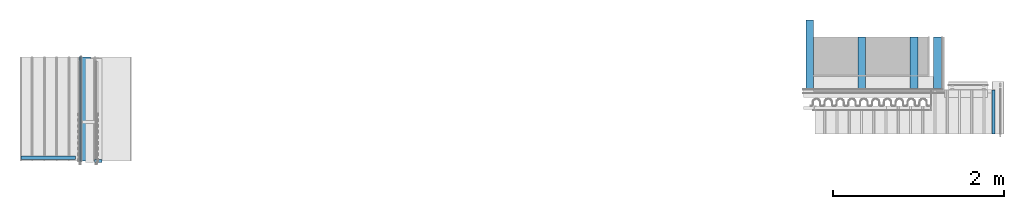
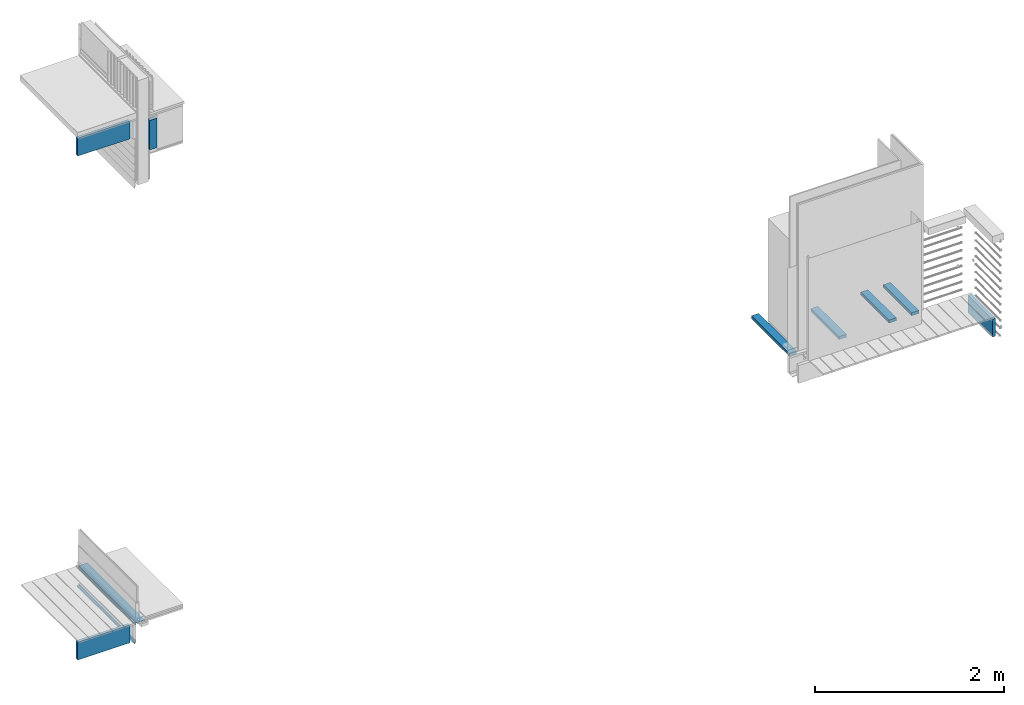
# One storey, part 3 of 33: 12 walls.
"""IFC4 building model written with IfcOpenShell, lengths in feet."""

from ifc_helpers import new_model, entity, si_unit, converted_unit, derived_unit, direction, frame, frame_2d, origin, origin_2d_with_axis, place, context, subcontext, project, spatial, rectangle, extrude, material, type_object, element, save


model = new_model("IFC4")

# Units and contexts
model_context = context("Model", 3, precision=0.0001, world=origin(), true_north=direction((6.12303176911189e-17, 1.0)))
body_context = subcontext(model_context, "Body", "Model", "MODEL_VIEW")
ifc_project = project(units=[converted_unit("LENGTHUNIT", "FOOT", entity("IfcRatioMeasure", 0.3048), si_unit("LENGTHUNIT", "METRE"), dimensions=[1, 0, 0, 0, 0, 0, 0]), converted_unit("AREAUNIT", "SQUARE FOOT", entity("IfcRatioMeasure", 0.09290304), si_unit("AREAUNIT", "SQUARE_METRE"), dimensions=[2, 0, 0, 0, 0, 0, 0]), converted_unit("VOLUMEUNIT", "CUBIC FOOT", entity("IfcRatioMeasure", 0.028316846592), si_unit("VOLUMEUNIT", "CUBIC_METRE"), dimensions=[3, 0, 0, 0, 0, 0, 0]), converted_unit("PLANEANGLEUNIT", "DEGREE", entity("IfcRatioMeasure", 0.0174532925199433), si_unit("PLANEANGLEUNIT", "RADIAN"), dimensions=[0, 0, 0, 0, 0, 0, 0]), si_unit("MASSUNIT", "GRAM", prefix="KILO"), derived_unit("MASSDENSITYUNIT", [(si_unit("MASSUNIT", "GRAM", prefix="KILO"), 1), (si_unit("LENGTHUNIT", "METRE"), -3)]), derived_unit("MOMENTOFINERTIAUNIT", [(si_unit("LENGTHUNIT", "METRE"), 4)]), si_unit("TIMEUNIT", "SECOND"), si_unit("FREQUENCYUNIT", "HERTZ"), si_unit("THERMODYNAMICTEMPERATUREUNIT", "DEGREE_CELSIUS"), derived_unit("THERMALTRANSMITTANCEUNIT", [(si_unit("MASSUNIT", "GRAM", prefix="KILO"), 1), (si_unit("THERMODYNAMICTEMPERATUREUNIT", "KELVIN"), -1), (si_unit("TIMEUNIT", "SECOND"), -3)]), derived_unit("VOLUMETRICFLOWRATEUNIT", [(si_unit("LENGTHUNIT", "METRE"), 3), (si_unit("TIMEUNIT", "SECOND"), -1)]), si_unit("ELECTRICCURRENTUNIT", "AMPERE"), si_unit("ELECTRICVOLTAGEUNIT", "VOLT"), si_unit("POWERUNIT", "WATT"), si_unit("FORCEUNIT", "NEWTON"), si_unit("ILLUMINANCEUNIT", "LUX"), si_unit("LUMINOUSFLUXUNIT", "LUMEN"), si_unit("LUMINOUSINTENSITYUNIT", "CANDELA"), derived_unit("USERDEFINED", [(si_unit("MASSUNIT", "GRAM", prefix="KILO"), -1), (si_unit("LENGTHUNIT", "METRE"), -2), (si_unit("TIMEUNIT", "SECOND"), 3), (si_unit("LUMINOUSFLUXUNIT", "LUMEN"), 1)]), derived_unit("LINEARVELOCITYUNIT", [(si_unit("LENGTHUNIT", "METRE"), 1), (si_unit("TIMEUNIT", "SECOND"), -1)]), si_unit("PRESSUREUNIT", "PASCAL"), derived_unit("USERDEFINED", [(si_unit("LENGTHUNIT", "METRE"), -2), (si_unit("MASSUNIT", "GRAM", prefix="KILO"), 1), (si_unit("TIMEUNIT", "SECOND"), -2)]), derived_unit("LINEARFORCEUNIT", [(si_unit("MASSUNIT", "GRAM", prefix="KILO"), 1), (si_unit("LENGTHUNIT", "METRE"), 1), (si_unit("TIMEUNIT", "SECOND"), -2), (si_unit("LENGTHUNIT", "METRE"), -1)]), derived_unit("PLANARFORCEUNIT", [(si_unit("MASSUNIT", "GRAM", prefix="KILO"), 1), (si_unit("LENGTHUNIT", "METRE"), 1), (si_unit("TIMEUNIT", "SECOND"), -2), (si_unit("LENGTHUNIT", "METRE"), -2)])], contexts=[model_context])

# Site, building, storey
site_placement = place(None, origin())
site = spatial("IfcSite", under=ifc_project, at=site_placement, CompositionType="ELEMENT")
building_placement = place(site_placement, origin())
building = spatial("IfcBuilding", under=site, at=building_placement, CompositionType="ELEMENT")
storey_placement = place(building_placement, frame((0.0, 0.0, 10.0)))
storey = spatial("IfcBuildingStorey", under=building, at=storey_placement, Name="2ND FLOOR", CompositionType="ELEMENT", Elevation=10.0000000000002)

# Walls
ifc_material_1 = material(Name="2X10 JOISTS", Category="Materials")
wall_type_1 = type_object("IfcWallType", Name="Generic Models 640:Generic Models 1", PredefinedType="NOTDEFINED", material=ifc_material_1)
wall_1_placement = place(storey_placement, frame((1456.95945835455, 2.06770833332915, -0.136897457209544)))
element("IfcWall", 1, at=wall_1_placement, inside=storey, type_object=wall_type_1, material=ifc_material_1, Name="Generic Models 640:Generic Models 1", ObjectType="Generic Models 640:Generic Models 1", PredefinedType="NOTDEFINED", context=body_context, shape_type="SweptSolid", body=[
    extrude(rectangle(XDim=0.125000000000002, YDim=2.09466288714884, at=origin_2d_with_axis()), frame((1.04733144357442, 0.0625000000000062, 0.0), z_axis=(0.0, 0.0, 1.0), x_axis=(0.0, 1.0, 0.0)), (0.0, 0.0, 1.0), 0.75),
])
ifc_material_2 = material(Name="METAL FLASHING", Category="Materials")
wall_type_2 = type_object("IfcWallType", Name="Generic Models 677:Generic Models 1", PredefinedType="NOTDEFINED", material=ifc_material_2)
wall_2_placement = place(storey_placement, frame((1459.20382006859, 2.0, -0.195608483354219), z_axis=(0.0, 0.0, 1.0), x_axis=(0.0, 1.0, 0.0)))
cartesian_point_1 = entity("IfcCartesianPoint", [4.0, -0.0556819070638994, 0.136863440335031])
vertex_point_1 = entity("IfcVertexPoint", cartesian_point_1)
cartesian_point_2 = entity("IfcCartesianPoint", [4.0, -0.0590152403972297, 0.136863440335031])
vertex_point_2 = entity("IfcVertexPoint", cartesian_point_2)
ifc_direction_1 = entity("IfcDirection", [0.0, -1.0, 0.0])
edge_curve_1 = entity("IfcEdgeCurve", vertex_point_1, vertex_point_2, entity("IfcTrimmedCurve", entity("IfcLine", cartesian_point_1, entity("IfcVector", ifc_direction_1, 1.0)), [cartesian_point_1], [cartesian_point_2], True, "CARTESIAN"), True)
cartesian_point_3 = entity("IfcCartesianPoint", [4.0, -0.0590152403972297, 0.0530392484579103])
vertex_point_3 = entity("IfcVertexPoint", cartesian_point_3)
ifc_direction_2 = entity("IfcDirection", [0.0, 0.0, -1.0])
edge_curve_2 = entity("IfcEdgeCurve", vertex_point_2, vertex_point_3, entity("IfcTrimmedCurve", entity("IfcLine", cartesian_point_2, entity("IfcVector", ifc_direction_2, 1.0)), [cartesian_point_2], [cartesian_point_3], True, "CARTESIAN"), True)
cartesian_point_4 = entity("IfcCartesianPoint", [4.0, -0.00778096922499572, 0.0530392484579103])
vertex_point_4 = entity("IfcVertexPoint", cartesian_point_4)
ifc_direction_3 = entity("IfcDirection", [0.0, 1.0, 0.0])
edge_curve_3 = entity("IfcEdgeCurve", vertex_point_3, vertex_point_4, entity("IfcTrimmedCurve", entity("IfcLine", cartesian_point_3, entity("IfcVector", ifc_direction_3, 1.0)), [cartesian_point_3], [cartesian_point_4], True, "CARTESIAN"), True)
cartesian_point_5 = entity("IfcCartesianPoint", [4.0, -0.00326697603304638, 0.0])
vertex_point_5 = entity("IfcVertexPoint", cartesian_point_5)
edge_curve_4 = entity("IfcEdgeCurve", vertex_point_4, vertex_point_5, entity("IfcTrimmedCurve", entity("IfcLine", cartesian_point_4, entity("IfcVector", entity("IfcDirection", [0.0, 0.0848001027005372, -0.996397984031471]), 1.0)), [cartesian_point_4], [cartesian_point_5], True, "CARTESIAN"), True)
cartesian_point_6 = entity("IfcCartesianPoint", [4.0, 0.0, 0.0])
vertex_point_6 = entity("IfcVertexPoint", cartesian_point_6)
edge_curve_5 = entity("IfcEdgeCurve", vertex_point_5, vertex_point_6, entity("IfcTrimmedCurve", entity("IfcLine", cartesian_point_5, entity("IfcVector", ifc_direction_3, 1.0)), [cartesian_point_5], [cartesian_point_6], True, "CARTESIAN"), True)
cartesian_point_7 = entity("IfcCartesianPoint", [4.0, -0.00480094715771884, 0.0564109466517415])
vertex_point_7 = entity("IfcVertexPoint", cartesian_point_7)
edge_curve_6 = entity("IfcEdgeCurve", vertex_point_6, vertex_point_7, entity("IfcTrimmedCurve", entity("IfcLine", cartesian_point_6, entity("IfcVector", entity("IfcDirection", [0.0, -0.08480010269862, 0.996397984031634]), 1.0)), [cartesian_point_6], [cartesian_point_7], True, "CARTESIAN"), True)
cartesian_point_8 = entity("IfcCartesianPoint", [4.0, -0.0556819070638994, 0.0564109466517415])
vertex_point_8 = entity("IfcVertexPoint", cartesian_point_8)
edge_curve_7 = entity("IfcEdgeCurve", vertex_point_7, vertex_point_8, entity("IfcTrimmedCurve", entity("IfcLine", cartesian_point_7, entity("IfcVector", ifc_direction_1, 1.0)), [cartesian_point_7], [cartesian_point_8], True, "CARTESIAN"), True)
ifc_direction_4 = entity("IfcDirection", [0.0, 0.0, 1.0])
edge_curve_8 = entity("IfcEdgeCurve", vertex_point_8, vertex_point_1, entity("IfcTrimmedCurve", entity("IfcLine", cartesian_point_8, entity("IfcVector", ifc_direction_4, 1.0)), [cartesian_point_8], [cartesian_point_1], True, "CARTESIAN"), True)
ifc_direction_5 = entity("IfcDirection", [1.0, 0.0, 0.0])
cartesian_point_9 = entity("IfcCartesianPoint", [0.0, -0.0556819070638994, 0.136863440335038])
vertex_point_9 = entity("IfcVertexPoint", cartesian_point_9)
cartesian_point_10 = entity("IfcCartesianPoint", [0.0, -0.0556819070638994, 0.0564109466517486])
vertex_point_10 = entity("IfcVertexPoint", cartesian_point_10)
edge_curve_9 = entity("IfcEdgeCurve", vertex_point_9, vertex_point_10, entity("IfcTrimmedCurve", entity("IfcLine", cartesian_point_9, entity("IfcVector", ifc_direction_2, 1.0)), [cartesian_point_9], [cartesian_point_10], True, "CARTESIAN"), True)
cartesian_point_11 = entity("IfcCartesianPoint", [0.0, -0.00480094715771884, 0.0564109466517486])
vertex_point_11 = entity("IfcVertexPoint", cartesian_point_11)
edge_curve_10 = entity("IfcEdgeCurve", vertex_point_10, vertex_point_11, entity("IfcTrimmedCurve", entity("IfcLine", cartesian_point_10, entity("IfcVector", ifc_direction_3, 1.0)), [cartesian_point_10], [cartesian_point_11], True, "CARTESIAN"), True)
cartesian_point_12 = entity("IfcCartesianPoint", [0.0, 0.0, 0.0])
vertex_point_12 = entity("IfcVertexPoint", cartesian_point_12)
edge_curve_11 = entity("IfcEdgeCurve", vertex_point_11, vertex_point_12, entity("IfcTrimmedCurve", entity("IfcLine", cartesian_point_11, entity("IfcVector", entity("IfcDirection", [0.0, 0.08480010269862, -0.996397984031634]), 1.0)), [cartesian_point_11], [cartesian_point_12], True, "CARTESIAN"), True)
cartesian_point_13 = entity("IfcCartesianPoint", [0.0, -0.00326697603304638, 0.0])
vertex_point_13 = entity("IfcVertexPoint", cartesian_point_13)
edge_curve_12 = entity("IfcEdgeCurve", vertex_point_12, vertex_point_13, entity("IfcTrimmedCurve", entity("IfcLine", cartesian_point_12, entity("IfcVector", ifc_direction_1, 1.0)), [cartesian_point_12], [cartesian_point_13], True, "CARTESIAN"), True)
cartesian_point_14 = entity("IfcCartesianPoint", [0.0, -0.00778096922499572, 0.0530392484579174])
vertex_point_14 = entity("IfcVertexPoint", cartesian_point_14)
edge_curve_13 = entity("IfcEdgeCurve", vertex_point_13, vertex_point_14, entity("IfcTrimmedCurve", entity("IfcLine", cartesian_point_13, entity("IfcVector", entity("IfcDirection", [0.0, -0.0848001027005372, 0.996397984031471]), 1.0)), [cartesian_point_13], [cartesian_point_14], True, "CARTESIAN"), True)
cartesian_point_15 = entity("IfcCartesianPoint", [0.0, -0.0590152403972297, 0.0530392484579174])
vertex_point_15 = entity("IfcVertexPoint", cartesian_point_15)
edge_curve_14 = entity("IfcEdgeCurve", vertex_point_14, vertex_point_15, entity("IfcTrimmedCurve", entity("IfcLine", cartesian_point_14, entity("IfcVector", ifc_direction_1, 1.0)), [cartesian_point_14], [cartesian_point_15], True, "CARTESIAN"), True)
cartesian_point_16 = entity("IfcCartesianPoint", [0.0, -0.0590152403972297, 0.136863440335038])
vertex_point_16 = entity("IfcVertexPoint", cartesian_point_16)
edge_curve_15 = entity("IfcEdgeCurve", vertex_point_15, vertex_point_16, entity("IfcTrimmedCurve", entity("IfcLine", cartesian_point_15, entity("IfcVector", ifc_direction_4, 1.0)), [cartesian_point_15], [cartesian_point_16], True, "CARTESIAN"), True)
edge_curve_16 = entity("IfcEdgeCurve", vertex_point_16, vertex_point_9, entity("IfcTrimmedCurve", entity("IfcLine", cartesian_point_16, entity("IfcVector", ifc_direction_3, 1.0)), [cartesian_point_16], [cartesian_point_9], True, "CARTESIAN"), True)
ifc_direction_6 = entity("IfcDirection", [-1.0, 0.0, 0.0])
edge_curve_17 = entity("IfcEdgeCurve", vertex_point_15, vertex_point_3, entity("IfcTrimmedCurve", entity("IfcLine", cartesian_point_15, entity("IfcVector", ifc_direction_5, 1.0)), [cartesian_point_15], [cartesian_point_3], True, "CARTESIAN"), True)
edge_curve_18 = entity("IfcEdgeCurve", vertex_point_2, vertex_point_16, entity("IfcTrimmedCurve", entity("IfcLine", cartesian_point_16, entity("IfcVector", ifc_direction_6, 1.0)), [cartesian_point_2], [cartesian_point_16], True, "CARTESIAN"), True)
edge_curve_19 = entity("IfcEdgeCurve", vertex_point_9, vertex_point_1, entity("IfcTrimmedCurve", entity("IfcLine", cartesian_point_9, entity("IfcVector", ifc_direction_5, 1.0)), [cartesian_point_9], [cartesian_point_1], True, "CARTESIAN"), True)
edge_curve_20 = entity("IfcEdgeCurve", vertex_point_8, vertex_point_10, entity("IfcTrimmedCurve", entity("IfcLine", cartesian_point_10, entity("IfcVector", ifc_direction_6, 1.0)), [cartesian_point_8], [cartesian_point_10], True, "CARTESIAN"), True)
edge_curve_21 = entity("IfcEdgeCurve", vertex_point_7, vertex_point_11, entity("IfcTrimmedCurve", entity("IfcLine", cartesian_point_11, entity("IfcVector", ifc_direction_6, 1.0)), [cartesian_point_7], [cartesian_point_11], True, "CARTESIAN"), True)
edge_curve_22 = entity("IfcEdgeCurve", vertex_point_6, vertex_point_12, entity("IfcTrimmedCurve", entity("IfcLine", cartesian_point_12, entity("IfcVector", ifc_direction_6, 1.0)), [cartesian_point_6], [cartesian_point_12], True, "CARTESIAN"), True)
edge_curve_23 = entity("IfcEdgeCurve", vertex_point_5, vertex_point_13, entity("IfcTrimmedCurve", entity("IfcLine", cartesian_point_13, entity("IfcVector", ifc_direction_6, 1.0)), [cartesian_point_5], [cartesian_point_13], True, "CARTESIAN"), True)
edge_curve_24 = entity("IfcEdgeCurve", vertex_point_4, vertex_point_14, entity("IfcTrimmedCurve", entity("IfcLine", cartesian_point_14, entity("IfcVector", ifc_direction_6, 1.0)), [cartesian_point_4], [cartesian_point_14], True, "CARTESIAN"), True)
element("IfcWall", 2, at=wall_2_placement, inside=storey, type_object=wall_type_2, material=ifc_material_2, Name="Generic Models 677:Generic Models 1", ObjectType="Generic Models 677:Generic Models 1", PredefinedType="NOTDEFINED", context=body_context, shape_type="AdvancedBrep", body=[
    entity("IfcAdvancedBrep", entity("IfcClosedShell", [entity("IfcAdvancedFace", [entity("IfcFaceOuterBound", entity("IfcEdgeLoop", [entity("IfcOrientedEdge", None, None, edge_curve_1, True), entity("IfcOrientedEdge", None, None, edge_curve_2, True), entity("IfcOrientedEdge", None, None, edge_curve_3, True), entity("IfcOrientedEdge", None, None, edge_curve_4, True), entity("IfcOrientedEdge", None, None, edge_curve_5, True), entity("IfcOrientedEdge", None, None, edge_curve_6, True), entity("IfcOrientedEdge", None, None, edge_curve_7, True), entity("IfcOrientedEdge", None, None, edge_curve_8, True)]), True)], entity("IfcPlane", entity("IfcAxis2Placement3D", entity("IfcCartesianPoint", [4.0, -0.0556819070638994, -9.23241093280805]), ifc_direction_5, ifc_direction_4)), True), entity("IfcAdvancedFace", [entity("IfcFaceOuterBound", entity("IfcEdgeLoop", [entity("IfcOrientedEdge", None, None, edge_curve_9, True), entity("IfcOrientedEdge", None, None, edge_curve_10, True), entity("IfcOrientedEdge", None, None, edge_curve_11, True), entity("IfcOrientedEdge", None, None, edge_curve_12, True), entity("IfcOrientedEdge", None, None, edge_curve_13, True), entity("IfcOrientedEdge", None, None, edge_curve_14, True), entity("IfcOrientedEdge", None, None, edge_curve_15, True), entity("IfcOrientedEdge", None, None, edge_curve_16, True)]), True)], entity("IfcPlane", entity("IfcAxis2Placement3D", entity("IfcCartesianPoint", [0.0, -0.0556819070638994, -9.23241093280804]), ifc_direction_6, ifc_direction_2)), True), entity("IfcAdvancedFace", [entity("IfcFaceOuterBound", entity("IfcEdgeLoop", [entity("IfcOrientedEdge", None, None, edge_curve_15, False), entity("IfcOrientedEdge", None, None, edge_curve_17, True), entity("IfcOrientedEdge", None, None, edge_curve_2, False), entity("IfcOrientedEdge", None, None, edge_curve_18, True)]), True)], entity("IfcPlane", entity("IfcAxis2Placement3D", cartesian_point_15, ifc_direction_1, ifc_direction_5)), True), entity("IfcAdvancedFace", [entity("IfcFaceOuterBound", entity("IfcEdgeLoop", [entity("IfcOrientedEdge", None, None, edge_curve_9, False), entity("IfcOrientedEdge", None, None, edge_curve_19, True), entity("IfcOrientedEdge", None, None, edge_curve_8, False), entity("IfcOrientedEdge", None, None, edge_curve_20, True)]), True)], entity("IfcPlane", entity("IfcAxis2Placement3D", cartesian_point_9, ifc_direction_3, ifc_direction_5)), True), entity("IfcAdvancedFace", [entity("IfcFaceOuterBound", entity("IfcEdgeLoop", [entity("IfcOrientedEdge", None, None, edge_curve_10, False), entity("IfcOrientedEdge", None, None, edge_curve_20, False), entity("IfcOrientedEdge", None, None, edge_curve_7, False), entity("IfcOrientedEdge", None, None, edge_curve_21, True)]), True)], entity("IfcPlane", entity("IfcAxis2Placement3D", cartesian_point_10, ifc_direction_4, ifc_direction_5)), True), entity("IfcAdvancedFace", [entity("IfcFaceOuterBound", entity("IfcEdgeLoop", [entity("IfcOrientedEdge", None, None, edge_curve_11, False), entity("IfcOrientedEdge", None, None, edge_curve_21, False), entity("IfcOrientedEdge", None, None, edge_curve_6, False), entity("IfcOrientedEdge", None, None, edge_curve_22, True)]), True)], entity("IfcPlane", entity("IfcAxis2Placement3D", cartesian_point_11, entity("IfcDirection", [0.0, 0.996397984031633, 0.0848001026986226]), ifc_direction_5)), True), entity("IfcAdvancedFace", [entity("IfcFaceOuterBound", entity("IfcEdgeLoop", [entity("IfcOrientedEdge", None, None, edge_curve_12, False), entity("IfcOrientedEdge", None, None, edge_curve_22, False), entity("IfcOrientedEdge", None, None, edge_curve_5, False), entity("IfcOrientedEdge", None, None, edge_curve_23, True)]), True)], entity("IfcPlane", entity("IfcAxis2Placement3D", cartesian_point_12, ifc_direction_2, ifc_direction_5)), True), entity("IfcAdvancedFace", [entity("IfcFaceOuterBound", entity("IfcEdgeLoop", [entity("IfcOrientedEdge", None, None, edge_curve_13, False), entity("IfcOrientedEdge", None, None, edge_curve_23, False), entity("IfcOrientedEdge", None, None, edge_curve_4, False), entity("IfcOrientedEdge", None, None, edge_curve_24, True)]), True)], entity("IfcPlane", entity("IfcAxis2Placement3D", cartesian_point_13, entity("IfcDirection", [0.0, -0.99639798403147, -0.0848001027005386]), ifc_direction_5)), True), entity("IfcAdvancedFace", [entity("IfcFaceOuterBound", entity("IfcEdgeLoop", [entity("IfcOrientedEdge", None, None, edge_curve_14, False), entity("IfcOrientedEdge", None, None, edge_curve_24, False), entity("IfcOrientedEdge", None, None, edge_curve_3, False), entity("IfcOrientedEdge", None, None, edge_curve_17, False)]), True)], entity("IfcPlane", entity("IfcAxis2Placement3D", cartesian_point_14, ifc_direction_2, ifc_direction_5)), True), entity("IfcAdvancedFace", [entity("IfcFaceOuterBound", entity("IfcEdgeLoop", [entity("IfcOrientedEdge", None, None, edge_curve_16, False), entity("IfcOrientedEdge", None, None, edge_curve_18, False), entity("IfcOrientedEdge", None, None, edge_curve_1, False), entity("IfcOrientedEdge", None, None, edge_curve_19, False)]), True)], entity("IfcPlane", entity("IfcAxis2Placement3D", cartesian_point_16, ifc_direction_4, ifc_direction_5)), True)])),
])
ifc_material_3 = material(Name="FLEXIBLE FLASHING", Category="Materials")
wall_type_3 = type_object("IfcWallType", Name="Generic Models 651:Generic Models 1", PredefinedType="NOTDEFINED", material=ifc_material_3)
wall_3_placement = place(storey_placement, frame((1459.25920396212, 2.0, 0.545613467849234), z_axis=(0.0, 0.0, 1.0), x_axis=(0.0, 1.0, 0.0)))
cartesian_point_17 = entity("IfcCartesianPoint", [4.0, 0.0, 0.130726986291695])
vertex_point_17 = entity("IfcVertexPoint", cartesian_point_17)
cartesian_point_18 = entity("IfcCartesianPoint", [4.0, -0.352179035002109, 0.130726986291695])
vertex_point_18 = entity("IfcVertexPoint", cartesian_point_18)
ifc_direction_7 = entity("IfcDirection", [0.0, -1.0, 0.0])
edge_curve_25 = entity("IfcEdgeCurve", vertex_point_17, vertex_point_18, entity("IfcTrimmedCurve", entity("IfcLine", cartesian_point_17, entity("IfcVector", ifc_direction_7, 1.0)), [cartesian_point_17], [cartesian_point_18], True, "CARTESIAN"), True)
cartesian_point_19 = entity("IfcCartesianPoint", [4.0, -0.352179035002109, 0.127471777958363])
vertex_point_19 = entity("IfcVertexPoint", cartesian_point_19)
ifc_direction_8 = entity("IfcDirection", [0.0, 0.0, -1.0])
edge_curve_26 = entity("IfcEdgeCurve", vertex_point_18, vertex_point_19, entity("IfcTrimmedCurve", entity("IfcLine", cartesian_point_18, entity("IfcVector", ifc_direction_8, 1.0)), [cartesian_point_18], [cartesian_point_19], True, "CARTESIAN"), True)
cartesian_point_20 = entity("IfcCartesianPoint", [4.0, -0.0033333333333303, 0.127471777958363])
vertex_point_20 = entity("IfcVertexPoint", cartesian_point_20)
ifc_direction_9 = entity("IfcDirection", [0.0, 1.0, 0.0])
edge_curve_27 = entity("IfcEdgeCurve", vertex_point_19, vertex_point_20, entity("IfcTrimmedCurve", entity("IfcLine", cartesian_point_19, entity("IfcVector", ifc_direction_9, 1.0)), [cartesian_point_19], [cartesian_point_20], True, "CARTESIAN"), True)
cartesian_point_21 = entity("IfcCartesianPoint", [4.0, -0.0033333333333303, 0.0])
vertex_point_21 = entity("IfcVertexPoint", cartesian_point_21)
edge_curve_28 = entity("IfcEdgeCurve", vertex_point_20, vertex_point_21, entity("IfcTrimmedCurve", entity("IfcLine", cartesian_point_20, entity("IfcVector", ifc_direction_8, 1.0)), [cartesian_point_20], [cartesian_point_21], True, "CARTESIAN"), True)
cartesian_point_22 = entity("IfcCartesianPoint", [4.0, 0.0, 0.0])
vertex_point_22 = entity("IfcVertexPoint", cartesian_point_22)
edge_curve_29 = entity("IfcEdgeCurve", vertex_point_21, vertex_point_22, entity("IfcTrimmedCurve", entity("IfcLine", cartesian_point_21, entity("IfcVector", ifc_direction_9, 1.0)), [cartesian_point_21], [cartesian_point_22], True, "CARTESIAN"), True)
ifc_direction_10 = entity("IfcDirection", [0.0, 0.0, 1.0])
edge_curve_30 = entity("IfcEdgeCurve", vertex_point_22, vertex_point_17, entity("IfcTrimmedCurve", entity("IfcLine", cartesian_point_22, entity("IfcVector", ifc_direction_10, 1.0)), [cartesian_point_22], [cartesian_point_17], True, "CARTESIAN"), True)
ifc_direction_11 = entity("IfcDirection", [1.0, 0.0, 0.0])
cartesian_point_23 = entity("IfcCartesianPoint", [0.0, 0.0, 0.130726986291702])
vertex_point_23 = entity("IfcVertexPoint", cartesian_point_23)
cartesian_point_24 = entity("IfcCartesianPoint", [0.0, 0.0, 0.0])
vertex_point_24 = entity("IfcVertexPoint", cartesian_point_24)
edge_curve_31 = entity("IfcEdgeCurve", vertex_point_23, vertex_point_24, entity("IfcTrimmedCurve", entity("IfcLine", cartesian_point_23, entity("IfcVector", ifc_direction_8, 1.0)), [cartesian_point_23], [cartesian_point_24], True, "CARTESIAN"), True)
cartesian_point_25 = entity("IfcCartesianPoint", [0.0, -0.0033333333333303, 0.0])
vertex_point_25 = entity("IfcVertexPoint", cartesian_point_25)
edge_curve_32 = entity("IfcEdgeCurve", vertex_point_24, vertex_point_25, entity("IfcTrimmedCurve", entity("IfcLine", cartesian_point_24, entity("IfcVector", ifc_direction_7, 1.0)), [cartesian_point_24], [cartesian_point_25], True, "CARTESIAN"), True)
cartesian_point_26 = entity("IfcCartesianPoint", [0.0, -0.0033333333333303, 0.12747177795837])
vertex_point_26 = entity("IfcVertexPoint", cartesian_point_26)
edge_curve_33 = entity("IfcEdgeCurve", vertex_point_25, vertex_point_26, entity("IfcTrimmedCurve", entity("IfcLine", cartesian_point_25, entity("IfcVector", ifc_direction_10, 1.0)), [cartesian_point_25], [cartesian_point_26], True, "CARTESIAN"), True)
cartesian_point_27 = entity("IfcCartesianPoint", [0.0, -0.352179035002109, 0.12747177795837])
vertex_point_27 = entity("IfcVertexPoint", cartesian_point_27)
edge_curve_34 = entity("IfcEdgeCurve", vertex_point_26, vertex_point_27, entity("IfcTrimmedCurve", entity("IfcLine", cartesian_point_26, entity("IfcVector", ifc_direction_7, 1.0)), [cartesian_point_26], [cartesian_point_27], True, "CARTESIAN"), True)
cartesian_point_28 = entity("IfcCartesianPoint", [0.0, -0.352179035002109, 0.130726986291702])
vertex_point_28 = entity("IfcVertexPoint", cartesian_point_28)
edge_curve_35 = entity("IfcEdgeCurve", vertex_point_27, vertex_point_28, entity("IfcTrimmedCurve", entity("IfcLine", cartesian_point_27, entity("IfcVector", ifc_direction_10, 1.0)), [cartesian_point_27], [cartesian_point_28], True, "CARTESIAN"), True)
edge_curve_36 = entity("IfcEdgeCurve", vertex_point_28, vertex_point_23, entity("IfcTrimmedCurve", entity("IfcLine", cartesian_point_28, entity("IfcVector", ifc_direction_9, 1.0)), [cartesian_point_28], [cartesian_point_23], True, "CARTESIAN"), True)
ifc_direction_12 = entity("IfcDirection", [-1.0, 0.0, 0.0])
edge_curve_37 = entity("IfcEdgeCurve", vertex_point_25, vertex_point_21, entity("IfcTrimmedCurve", entity("IfcLine", cartesian_point_25, entity("IfcVector", ifc_direction_11, 1.0)), [cartesian_point_25], [cartesian_point_21], True, "CARTESIAN"), True)
edge_curve_38 = entity("IfcEdgeCurve", vertex_point_20, vertex_point_26, entity("IfcTrimmedCurve", entity("IfcLine", cartesian_point_26, entity("IfcVector", ifc_direction_12, 1.0)), [cartesian_point_20], [cartesian_point_26], True, "CARTESIAN"), True)
edge_curve_39 = entity("IfcEdgeCurve", vertex_point_23, vertex_point_17, entity("IfcTrimmedCurve", entity("IfcLine", cartesian_point_23, entity("IfcVector", ifc_direction_11, 1.0)), [cartesian_point_23], [cartesian_point_17], True, "CARTESIAN"), True)
edge_curve_40 = entity("IfcEdgeCurve", vertex_point_22, vertex_point_24, entity("IfcTrimmedCurve", entity("IfcLine", cartesian_point_24, entity("IfcVector", ifc_direction_12, 1.0)), [cartesian_point_22], [cartesian_point_24], True, "CARTESIAN"), True)
edge_curve_41 = entity("IfcEdgeCurve", vertex_point_19, vertex_point_27, entity("IfcTrimmedCurve", entity("IfcLine", cartesian_point_27, entity("IfcVector", ifc_direction_12, 1.0)), [cartesian_point_19], [cartesian_point_27], True, "CARTESIAN"), True)
edge_curve_42 = entity("IfcEdgeCurve", vertex_point_18, vertex_point_28, entity("IfcTrimmedCurve", entity("IfcLine", cartesian_point_28, entity("IfcVector", ifc_direction_12, 1.0)), [cartesian_point_18], [cartesian_point_28], True, "CARTESIAN"), True)
element("IfcWall", 3, at=wall_3_placement, inside=storey, type_object=wall_type_3, material=ifc_material_3, Name="Generic Models 651:Generic Models 1", ObjectType="Generic Models 651:Generic Models 1", PredefinedType="NOTDEFINED", context=body_context, shape_type="AdvancedBrep", body=[
    entity("IfcAdvancedBrep", entity("IfcClosedShell", [entity("IfcAdvancedFace", [entity("IfcFaceOuterBound", entity("IfcEdgeLoop", [entity("IfcOrientedEdge", None, None, edge_curve_25, True), entity("IfcOrientedEdge", None, None, edge_curve_26, True), entity("IfcOrientedEdge", None, None, edge_curve_27, True), entity("IfcOrientedEdge", None, None, edge_curve_28, True), entity("IfcOrientedEdge", None, None, edge_curve_29, True), entity("IfcOrientedEdge", None, None, edge_curve_30, True)]), True)], entity("IfcPlane", entity("IfcAxis2Placement3D", entity("IfcCartesianPoint", [4.0, 0.0, -9.91419488870765]), ifc_direction_11, ifc_direction_10)), True), entity("IfcAdvancedFace", [entity("IfcFaceOuterBound", entity("IfcEdgeLoop", [entity("IfcOrientedEdge", None, None, edge_curve_31, True), entity("IfcOrientedEdge", None, None, edge_curve_32, True), entity("IfcOrientedEdge", None, None, edge_curve_33, True), entity("IfcOrientedEdge", None, None, edge_curve_34, True), entity("IfcOrientedEdge", None, None, edge_curve_35, True), entity("IfcOrientedEdge", None, None, edge_curve_36, True)]), True)], entity("IfcPlane", entity("IfcAxis2Placement3D", entity("IfcCartesianPoint", [0.0, 0.0, -9.91419488870764]), ifc_direction_12, ifc_direction_8)), True), entity("IfcAdvancedFace", [entity("IfcFaceOuterBound", entity("IfcEdgeLoop", [entity("IfcOrientedEdge", None, None, edge_curve_33, False), entity("IfcOrientedEdge", None, None, edge_curve_37, True), entity("IfcOrientedEdge", None, None, edge_curve_28, False), entity("IfcOrientedEdge", None, None, edge_curve_38, True)]), True)], entity("IfcPlane", entity("IfcAxis2Placement3D", cartesian_point_25, ifc_direction_7, ifc_direction_11)), True), entity("IfcAdvancedFace", [entity("IfcFaceOuterBound", entity("IfcEdgeLoop", [entity("IfcOrientedEdge", None, None, edge_curve_31, False), entity("IfcOrientedEdge", None, None, edge_curve_39, True), entity("IfcOrientedEdge", None, None, edge_curve_30, False), entity("IfcOrientedEdge", None, None, edge_curve_40, True)]), True)], entity("IfcPlane", entity("IfcAxis2Placement3D", cartesian_point_23, ifc_direction_9, ifc_direction_11)), True), entity("IfcAdvancedFace", [entity("IfcFaceOuterBound", entity("IfcEdgeLoop", [entity("IfcOrientedEdge", None, None, edge_curve_34, False), entity("IfcOrientedEdge", None, None, edge_curve_38, False), entity("IfcOrientedEdge", None, None, edge_curve_27, False), entity("IfcOrientedEdge", None, None, edge_curve_41, True)]), True)], entity("IfcPlane", entity("IfcAxis2Placement3D", cartesian_point_26, ifc_direction_8, ifc_direction_11)), True), entity("IfcAdvancedFace", [entity("IfcFaceOuterBound", entity("IfcEdgeLoop", [entity("IfcOrientedEdge", None, None, edge_curve_35, False), entity("IfcOrientedEdge", None, None, edge_curve_41, False), entity("IfcOrientedEdge", None, None, edge_curve_26, False), entity("IfcOrientedEdge", None, None, edge_curve_42, True)]), True)], entity("IfcPlane", entity("IfcAxis2Placement3D", cartesian_point_27, ifc_direction_7, ifc_direction_11)), True), entity("IfcAdvancedFace", [entity("IfcFaceOuterBound", entity("IfcEdgeLoop", [entity("IfcOrientedEdge", None, None, edge_curve_36, False), entity("IfcOrientedEdge", None, None, edge_curve_42, False), entity("IfcOrientedEdge", None, None, edge_curve_25, False), entity("IfcOrientedEdge", None, None, edge_curve_39, False)]), True)], entity("IfcPlane", entity("IfcAxis2Placement3D", cartesian_point_28, ifc_direction_10, ifc_direction_11)), True), entity("IfcAdvancedFace", [entity("IfcFaceOuterBound", entity("IfcEdgeLoop", [entity("IfcOrientedEdge", None, None, edge_curve_32, False), entity("IfcOrientedEdge", None, None, edge_curve_40, False), entity("IfcOrientedEdge", None, None, edge_curve_29, False), entity("IfcOrientedEdge", None, None, edge_curve_37, False)]), True)], entity("IfcPlane", entity("IfcAxis2Placement3D", cartesian_point_24, ifc_direction_8, ifc_direction_11)), True)])),
])
wall_type_4 = type_object("IfcWallType", Name="Generic Models 707:Generic Models 1", PredefinedType="NOTDEFINED", material=ifc_material_1)
wall_4_placement = place(storey_placement, frame((1456.95945835455, 2.06770833332916, 21.2083333333286)))
element("IfcWall", 4, at=wall_4_placement, inside=storey, type_object=wall_type_4, material=ifc_material_1, Name="Generic Models 707:Generic Models 1", ObjectType="Generic Models 707:Generic Models 1", PredefinedType="NOTDEFINED", context=body_context, shape_type="SweptSolid", body=[
    extrude(rectangle(XDim=0.125000000000002, YDim=2.09466288714884, at=origin_2d_with_axis()), frame((1.04733144357442, 0.0625000000000062, 0.0), z_axis=(0.0, 0.0, 1.0), x_axis=(0.0, 1.0, 0.0)), (0.0, 0.0, 1.0), 0.75),
])
ifc_material_4 = material(Name="WOOD TRUSS - SEE STRUCT", Category="Materials")
wall_type_5 = type_object("IfcWallType", Name="Generic Models 731:Generic Models 1", PredefinedType="NOTDEFINED", material=ifc_material_4)
wall_5_placement = place(storey_placement, frame((1459.76937904727, 1.94270833332915, 20.5624999999994)))
element("IfcWall", 5, at=wall_5_placement, inside=storey, type_object=wall_type_5, material=ifc_material_4, Name="Generic Models 731:Generic Models 1", ObjectType="Generic Models 731:Generic Models 1", PredefinedType="NOTDEFINED", context=body_context, shape_type="SweptSolid", body=[
    extrude(rectangle(XDim=0.125000000000002, YDim=0.291666666666742, at=frame_2d((1.11022302462516e-16, -1.13686837721616e-13), x_axis=(1.0, 0.0))), frame((0.145833333333258, 0.0625000000000011, 0.0), z_axis=(0.0, 0.0, 1.0), x_axis=(0.0, 1.0, 0.0)), (0.0, 0.0, 1.0), 1.25),
])
wall_type_6 = type_object("IfcWallType", Name="Walls 20:Walls 13", PredefinedType="NOTDEFINED", material=ifc_material_1)
wall_6_placement = place(storey_placement, frame((1494.16643519892, 3.04611392999272, -0.0744848494110784), z_axis=(0.0, 0.0, 1.0), x_axis=(0.0, 1.0, 0.0)))
element("IfcWall", 6, at=wall_6_placement, inside=storey, type_object=wall_type_6, material=ifc_material_1, Name="Walls 20:Walls 13", ObjectType="Walls 20:Walls 13", PredefinedType="NOTDEFINED", context=body_context, shape_type="SweptSolid", body=[
    extrude(rectangle(XDim=1.69297329192515, YDim=0.126590545719182, at=frame_2d((0.0, 1.13686837721616e-13), x_axis=(1.0, 0.0))), frame((0.846486645962577, -0.0632952728597047, 0.0)), (0.0, 0.0, 1.0), 0.752351056724386),
])
wall_type_7 = type_object("IfcWallType", Name="Generic Models 685:Generic Models 1", PredefinedType="NOTDEFINED", material=ifc_material_4)
wall_7_placement = place(storey_placement, frame((1491.03961782017, 4.79237630160339, 0.55226576487353), z_axis=(0.0, 0.0, 1.0), x_axis=(0.0, 1.0, 0.0)))
element("IfcWall", 7, at=wall_7_placement, inside=storey, type_object=wall_type_7, material=ifc_material_4, Name="Generic Models 685:Generic Models 1", ObjectType="Generic Models 685:Generic Models 1", PredefinedType="NOTDEFINED", context=body_context, shape_type="SweptSolid", body=[
    extrude(rectangle(XDim=1.97226557063841, YDim=0.291666666666515, at=origin_2d_with_axis()), frame((0.986132785319206, -0.145833333333258, 0.0)), (0.0, 0.0, 1.0), 0.125),
])
wall_type_8 = type_object("IfcWallType", Name="Generic Models 751:Generic Models 1", PredefinedType="NOTDEFINED", material=ifc_material_4)
wall_8_placement = place(storey_placement, frame((1491.94065948684, 4.78471920443274, 0.552265764873559), z_axis=(0.0, 0.0, 1.0), x_axis=(0.0, 1.0, 0.0)))
element("IfcWall", 8, at=wall_8_placement, inside=storey, type_object=wall_type_8, material=ifc_material_4, Name="Generic Models 751:Generic Models 1", ObjectType="Generic Models 751:Generic Models 1", PredefinedType="NOTDEFINED", context=body_context, shape_type="SweptSolid", body=[
    extrude(rectangle(XDim=1.97226557063841, YDim=0.291666666666515, at=frame_2d((-4.44089209850063e-16, 0.0), x_axis=(1.0, 0.0))), frame((0.986132785319207, -0.145833333333258, 0.0)), (0.0, 0.0, 1.0), 0.125),
])
wall_type_9 = type_object("IfcWallType", Name="Generic Models 682:Generic Models 1", PredefinedType="NOTDEFINED", material=ifc_material_4)
wall_9_placement = place(storey_placement, frame((1491.03961782017, 4.79237630160339, 0.55226576487353), z_axis=(0.0, 0.0, 1.0), x_axis=(0.0, 1.0, 0.0)))
element("IfcWall", 9, at=wall_9_placement, inside=storey, type_object=wall_type_9, material=ifc_material_4, Name="Generic Models 682:Generic Models 1", ObjectType="Generic Models 682:Generic Models 1", PredefinedType="NOTDEFINED", context=body_context, shape_type="SweptSolid", body=[
    extrude(rectangle(XDim=1.97226557063841, YDim=0.291666666666515, at=origin_2d_with_axis()), frame((0.986132785319206, -0.145833333333258, 0.0)), (0.0, 0.0, 1.0), 0.125),
])
wall_type_10 = type_object("IfcWallType", Name="Generic Models 759:Generic Models 1", PredefinedType="NOTDEFINED", material=ifc_material_4)
wall_10_placement = place(storey_placement, frame((1487.03961782017, 4.78805253776631, 0.552265764873551), z_axis=(0.0, 0.0, 1.0), x_axis=(0.0, 1.0, 0.0)))
element("IfcWall", 10, at=wall_10_placement, inside=storey, type_object=wall_type_10, material=ifc_material_4, Name="Generic Models 759:Generic Models 1", ObjectType="Generic Models 759:Generic Models 1", PredefinedType="NOTDEFINED", context=body_context, shape_type="SweptSolid", body=[
    extrude(rectangle(XDim=2.625, YDim=0.291666666666515, at=frame_2d((-4.44089209850063e-16, 0.0), x_axis=(1.0, 0.0))), frame((1.3125, -0.145833333333258, 0.0)), (0.0, 0.0, 1.0), 0.124999999999998),
])
wall_type_11 = type_object("IfcWallType", Name="Generic Models 773:Generic Models 1", PredefinedType="NOTDEFINED", material=ifc_material_4)
wall_11_placement = place(storey_placement, frame((1491.94065948684, 4.7880525377663, 0.552265764873559), z_axis=(0.0, 0.0, 1.0), x_axis=(0.0, 1.0, 0.0)))
element("IfcWall", 11, at=wall_11_placement, inside=storey, type_object=wall_type_11, material=ifc_material_4, Name="Generic Models 773:Generic Models 1", ObjectType="Generic Models 773:Generic Models 1", PredefinedType="NOTDEFINED", context=body_context, shape_type="SweptSolid", body=[
    extrude(rectangle(XDim=1.97226557063841, YDim=0.291666666666515, at=frame_2d((-4.44089209850063e-16, 0.0), x_axis=(1.0, 0.0))), frame((0.986132785319207, -0.145833333333258, 0.0)), (0.0, 0.0, 1.0), 0.125),
])
wall_type_12 = type_object("IfcWallType", Name="Generic Models 675:Generic Models 1", PredefinedType="NOTDEFINED", material=ifc_material_4)
wall_12_placement = place(storey_placement, frame((1489.03961782017, 4.7923763016034, 0.552265764873523), z_axis=(0.0, 0.0, 1.0), x_axis=(0.0, 1.0, 0.0)))
element("IfcWall", 12, at=wall_12_placement, inside=storey, type_object=wall_type_12, material=ifc_material_4, Name="Generic Models 675:Generic Models 1", ObjectType="Generic Models 675:Generic Models 1", PredefinedType="NOTDEFINED", context=body_context, shape_type="SweptSolid", body=[
    extrude(rectangle(XDim=1.97226557063841, YDim=0.291666666666515, at=frame_2d((-8.88178419700125e-16, 0.0), x_axis=(1.0, 0.0))), frame((0.986132785319207, -0.145833333333258, 0.0)), (0.0, 0.0, 1.0), 0.125),
])

save(model, "model.ifc")
